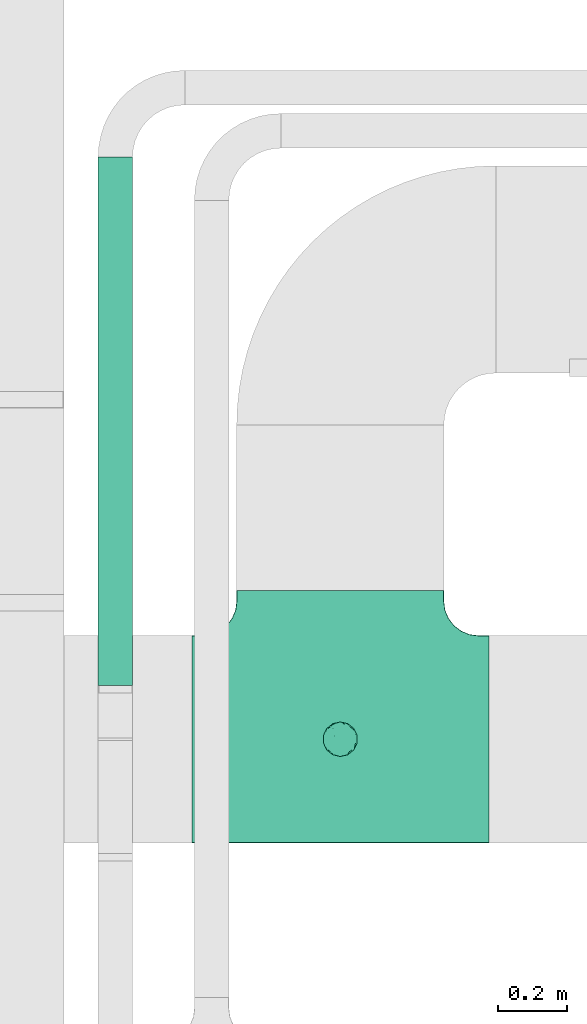
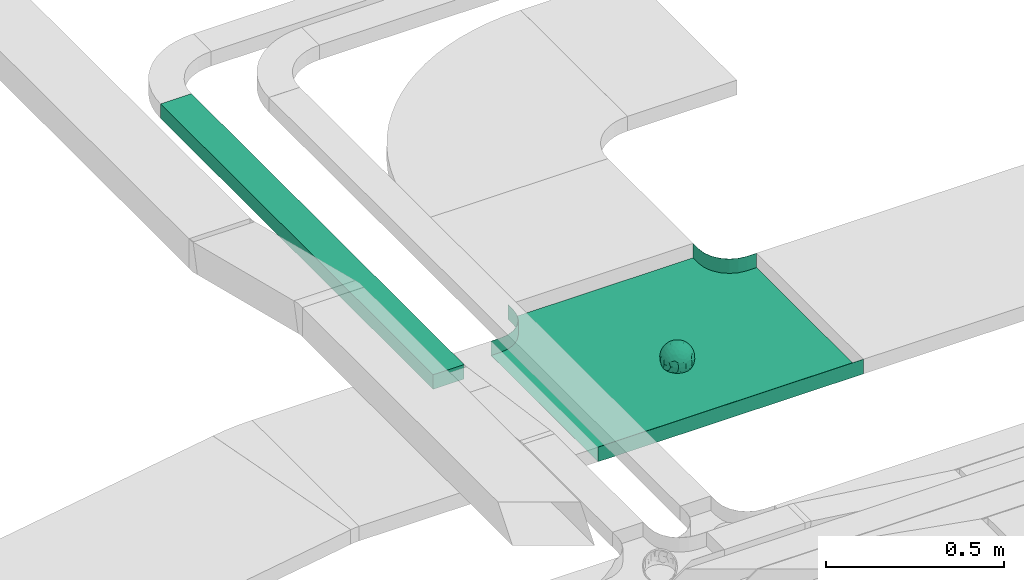
# One storey, part 4 of 38: 1 flow fitting, 1 flow segment.
"""IFC2X3 building model written with IfcOpenShell, lengths in millimetres."""

from ifc_helpers import new_model, entity, si_unit, converted_unit, derived_unit, direction, frame, frame_2d, origin, place, context, subcontext, project, spatial, rectangle, extrude, faceted_brep, source, transform, mapped, material, material_list, type_object, type_shapes, element, save


model = new_model("IFC2X3")

# Units and contexts
model_context = context("Model", 3, precision=0.01, world=origin(), true_north=direction((6.12303176911189e-17, 1.0)))
body_context = subcontext(model_context, "Body", "Model", "MODEL_VIEW")
ifc_project = project(units=[si_unit("LENGTHUNIT", "METRE", prefix="MILLI"), si_unit("AREAUNIT", "SQUARE_METRE"), si_unit("VOLUMEUNIT", "CUBIC_METRE"), converted_unit("PLANEANGLEUNIT", "DEGREE", entity("IfcRatioMeasure", 0.0174532925199433), si_unit("PLANEANGLEUNIT", "RADIAN"), dimensions=[0, 0, 0, 0, 0, 0, 0]), si_unit("MASSUNIT", "GRAM", prefix="KILO"), derived_unit("MASSDENSITYUNIT", [(si_unit("MASSUNIT", "GRAM", prefix="KILO"), 1), (si_unit("LENGTHUNIT", "METRE"), -3)]), derived_unit("MOMENTOFINERTIAUNIT", [(si_unit("LENGTHUNIT", "METRE"), 4)]), si_unit("TIMEUNIT", "SECOND"), si_unit("FREQUENCYUNIT", "HERTZ"), si_unit("THERMODYNAMICTEMPERATUREUNIT", "DEGREE_CELSIUS"), derived_unit("THERMALTRANSMITTANCEUNIT", [(si_unit("MASSUNIT", "GRAM", prefix="KILO"), 1), (si_unit("THERMODYNAMICTEMPERATUREUNIT", "KELVIN"), -1), (si_unit("TIMEUNIT", "SECOND"), -3)]), derived_unit("VOLUMETRICFLOWRATEUNIT", [(si_unit("LENGTHUNIT", "METRE"), 3), (si_unit("TIMEUNIT", "SECOND"), -1)]), derived_unit("MASSFLOWRATEUNIT", [(si_unit("MASSUNIT", "GRAM", prefix="KILO"), 1), (si_unit("TIMEUNIT", "SECOND"), -1)]), derived_unit("ROTATIONALFREQUENCYUNIT", [(si_unit("TIMEUNIT", "SECOND"), -1)]), si_unit("ELECTRICCURRENTUNIT", "AMPERE"), si_unit("ELECTRICVOLTAGEUNIT", "VOLT"), si_unit("POWERUNIT", "WATT"), si_unit("FORCEUNIT", "NEWTON", prefix="KILO"), si_unit("ILLUMINANCEUNIT", "LUX"), si_unit("LUMINOUSFLUXUNIT", "LUMEN"), si_unit("LUMINOUSINTENSITYUNIT", "CANDELA"), derived_unit("USERDEFINED", [(si_unit("MASSUNIT", "GRAM", prefix="KILO"), -1), (si_unit("LENGTHUNIT", "METRE"), -2), (si_unit("TIMEUNIT", "SECOND"), 3), (si_unit("LUMINOUSFLUXUNIT", "LUMEN"), 1)]), derived_unit("LINEARVELOCITYUNIT", [(si_unit("LENGTHUNIT", "METRE"), 1), (si_unit("TIMEUNIT", "SECOND"), -1)]), si_unit("PRESSUREUNIT", "PASCAL"), derived_unit("USERDEFINED", [(si_unit("LENGTHUNIT", "METRE"), -2), (si_unit("MASSUNIT", "GRAM", prefix="KILO"), 1), (si_unit("TIMEUNIT", "SECOND"), -2)]), derived_unit("LINEARFORCEUNIT", [(si_unit("MASSUNIT", "GRAM", prefix="KILO"), 1), (si_unit("LENGTHUNIT", "METRE"), 1), (si_unit("TIMEUNIT", "SECOND"), -2), (si_unit("LENGTHUNIT", "METRE"), -1)]), derived_unit("PLANARFORCEUNIT", [(si_unit("MASSUNIT", "GRAM", prefix="KILO"), 1), (si_unit("LENGTHUNIT", "METRE"), 1), (si_unit("TIMEUNIT", "SECOND"), -2), (si_unit("LENGTHUNIT", "METRE"), -2)])], contexts=[model_context])

# Site, building, storey
site_placement = place(None, frame((0.0, -0.00077364408347762, 0.0)))
site = spatial("IfcSite", under=ifc_project, at=site_placement, CompositionType="ELEMENT")
building_placement = place(site_placement, origin())
building = spatial("IfcBuilding", under=site, at=building_placement, CompositionType="ELEMENT")
storey_placement = place(building_placement, frame((0.0, 0.0, 4200.0)))
storey = spatial("IfcBuildingStorey", under=building, at=storey_placement, CompositionType="ELEMENT", Elevation=4200.0)

# Flow segment
cable_carrier_segment_type = type_object("IfcCableCarrierSegmentType", PredefinedType="CABLETRAYSEGMENT")
flow_segment_placement = place(storey_placement, frame((14783.0702916724, 13087.0410478205, 2750.0)))
element("IfcFlowSegment", 1, at=flow_segment_placement, inside=storey, type_object=cable_carrier_segment_type, context=body_context, shape_type="SweptSolid", body=[
    extrude(rectangle(XDim=1530.08411261918, YDim=99.9999999999989, at=frame_2d((0.0, -1.08357767203415e-12), x_axis=(1.0, 0.0))), frame((50.0, 765.042056309591, 0.0), z_axis=(0.0, 0.0, 1.0), x_axis=(0.0, -1.0, 0.0)), (0.0, 0.0, 1.0), 49.9999999999995),
])

# Flow fitting
ifc_material_1 = material()
ifc_material_2 = material()
ifc_material_list = material_list([ifc_material_1, ifc_material_2])
cable_carrier_fitting_type = type_object("IfcCableCarrierFittingType", PredefinedType="NOTDEFINED", material=ifc_material_1)
shared_shape = source(origin(), body_context, "Body", "Brep", [
    faceted_brep([(43.65414201495, -13.6159823941412, -20.221792907194), (44.7734537304832, 0.0, -22.2561865791168), (48.2627667869764, -5.5982238187369, -11.8053052540677), (16.6591030416451, 5.32882774998004, -46.8409850521773), (11.5556000970565, -8.32997143460759, -47.9278591457525), (2.01883462715812, 2.6979389970297, -49.8863250993269), (-7.81264210311725, -35.946586740035, -33.8645171988286), (-17.2052206683237, -38.2719861359275, -27.1888848422606), (-11.1277274207927, -27.3202044092451, -40.3705352142543), (37.7030088371667, -7.24923843471304, -32.0301680723234), (10.6384317789277, 26.5155476513889, -41.0335168128579), (19.2127839264957, 19.8412508508062, -41.6796556903778), (10.4192511908907, 17.8098221318595, -45.5439286870577), (48.7463956090969, 0.0, 0.0), (48.0667721403428, 6.51594663441988, -12.1296271775358), (-37.4554170352858, 12.1627069007925, -30.8084451986326), (-31.3452178059555, 12.1462454498318, -37.0127821457472), (-38.0909108580228, 3.52194087904066, -32.1974912446565), (48.7463956090969, 11.1260466978072, 0.0), (9.66670567763161, 42.5651334019307, -24.3877883338551), (17.4761229293595, 37.974251726212, -27.4324868211278), (8.3452685270067, 35.3634447252368, -34.3479733081336), (36.7018152786982, 20.4309971840494, -27.121045505536), (28.2201055605836, 12.5803931374896, -39.3110588849404), (28.3969378462537, 24.0066360557188, -33.4259681422047), (37.1036906899333, 7.75177236926259, -32.6071489449891), (30.3928805396455, 38.1114667440203, 0.0), (34.7422273315263, 34.6429784184742, 0.0), (32.9402906787036, 32.1278050479557, -19.5637775698511), (26.0435337477646, 41.5799550695664, 0.0), (-44.7734518080776, 0.0, -22.2561904464559), (-35.9183276906112, -8.71634506105637, -33.6734177755349), (-42.698067512074, -12.1858404892465, -22.9865247983333), (5.42354673897514, -48.7621108487887, 0.0), (2.92058716488888e-07, -48.7843224693665, -10.9585528791684), (7.58713024513234, -47.4313421101439, -13.8817592643935), (33.995370401777, -31.6485911362954, -18.5116576873667), (40.0066375577234, -26.2448741379086, -14.5146661281262), (30.3928805396453, -38.1114667440373, 0.0), (-47.5540080368347, -8.6499737676748, -12.798213682019), (43.918984866252, -21.1502683953847, 0.0), (-47.5463631702337, 8.67950108284767, -12.8066236860544), (-43.9189848662407, 21.1502683953677, 0.0), (-41.5587306666804, 23.544384411141, -14.7828910593852), (-36.7018137075475, 20.43099797302, -27.1210470373429), (-42.6812093094125, 12.162707383776, -23.0300438771125), (-0.0435489182880873, -44.6798423199703, -22.4434799831651), (43.3459115209922, 13.125713179152, -21.1860238825719), (-9.67158541810518, -42.815796006327, -23.9430166822217), (2.9348104480415, -38.3026865671621, -32.0045479482528), (10.5768620896568, -32.3565839798164, -36.6221444141874), (17.476122931187, -37.9742517249799, -27.4324868216925), (29.4150529887209, -14.2918330913411, -37.8219270339311), (29.2594402117981, 0.0, -40.5448536622337), (-34.742227331515, 34.6429784184742, 0.0), (-35.5934709721032, 30.8679809236437, -16.7413433706631), (16.2706402169142, 46.2863325463322, 0.0), (15.3978227309257, 45.3692296018892, -14.301750259225), (10.8470934779447, 47.524221697552, 0.0), (-22.0930685137321, 42.2576087042555, -15.0396419586498), (-16.2706402169028, 46.2863325463322, 0.0), (-15.3976096147999, 45.3685960862683, -14.3039892096614), (-35.5741674477324, -30.877857614309, -16.7641438657341), (-34.7422273315149, -34.6429784184913, 0.0), (-41.544749127214, -23.5699215759022, -14.7814957586296), (-21.2012609977656, -29.9118129495041, -33.9969113035032), (-22.0930685137892, -42.2576087036302, -15.0396419603704), (-28.5890959469058, -35.7745555449591, -20.0709932115786), (27.967317375364, -26.9235432392394, -31.5111405422078), (26.5630985649032, -36.7540375314827, -21.0604491824418), (-4.69743067705244, -12.8233951627736, -48.0988012484001), (-3.71385705669819, -22.0483048804436, -44.7222485756373), (7.046128924104e-07, -29.8515321197025, -40.1109215813634), (-8.78090686085946, 23.4705297392872, -43.266960933916), (-10.7087237416586, 12.1533783795858, -47.3034737602475), (-19.1851128431225, 19.8122800241045, -41.7061746680507), (19.2127839279743, -19.841250849511, -41.6796556903208), (10.2736167511021, -43.2535488218696, -22.8819429499797), (-16.2706402169027, -46.2863325463492, 0.0), (-15.4179487650123, -45.4307793041134, -14.0830091848577), (-10.8470934779332, -47.524221697569, 0.0), (-21.6941869558721, -45.0484433951294, 0.0), (-26.043533747753, -41.5799550695834, 0.0), (-30.3928805396339, -38.1114667440373, 0.0), (-26.9077773704145, -11.7097120961444, -40.4827637348157), (-28.5735237959864, -22.531789977659, -34.2909926698312), (-14.3485559949731, 0.554718003800719, -47.8937493708156), (20.3912706461748, 29.6966950280778, -34.6742323035854), (25.8798715159051, 35.5620355309087, -23.7817972243053), (-1.90439589452332, 38.2956374757213, -32.090768557389), (-0.0435489197807358, 44.6798423204566, -22.4434799821603), (-9.54280395759116, 42.6678856642021, -24.2566779582937), (-10.1209262269152, 33.0365306692783, -36.140759450321), (-17.2052206685055, 38.2719861378047, -27.1888848394794), (-28.5890959468196, 35.7745555453602, -20.0709932109564), (-30.3928805396341, 38.1114667440203, 0.0), (-26.0435337477532, 41.5799550695664, 0.0), (-21.6941869558723, 45.0484433951125, 0.0), (0.920553890736952, 16.9936143333855, -47.0145685125519), (7.01705705346737e-07, 29.8515321215381, -40.1109215799846), (-28.4299335912282, 23.6392950735915, -33.6589156750601), (22.0754283900311, -42.7194435884069, -13.7012627481666), (0.0, -50.0, 0.0), (-7.98433520770671, 47.2879675743241, -14.1456181900809), (-10.8470934779333, 47.524221697552, 0.0), (-5.42354673896381, 48.7621108487718, 0.0), (-39.0915741233958, -31.1744900929452, 0.0), (-36.7018137083218, -20.4309979729983, -27.1210470363242), (-20.0503020227076, 29.8835350153312, -34.7125297808217), (48.7463956090969, -11.1260466978243, 0.0), (36.7018152787698, -20.430997183803, -27.1210455056374), (39.0915741234071, -31.1744900929452, 0.0), (43.9189848662521, 21.1502683953677, 0.0), (41.0372234357161, 24.481336168204, -14.7176924857918), (21.4315363761966, -9.86715979165204, -44.0831986838696), (19.8461085062156, -30.3026908878047, -34.4656191315041), (26.0435337477644, -41.5799550695834, 0.0), (8.27678352490751, -22.6176025005053, -43.8171075221857), (-19.1851128386707, -19.8122800229913, -41.7061746706354), (-17.559283921422, -9.66340012518247, -45.8070982074481), (-29.2594384269524, -1.64502744759432e-09, -40.5448549502702), (-22.2759109836818, 8.45458562997746, -43.957977338265), (21.6941869558835, -45.0484433951294, 0.0), (-7.7537430917927, -47.3248906716555, -14.1504131029038), (22.0929359888287, 42.3611643932195, -14.7456410726513), (21.6941869558837, 45.0484433951125, 0.0), (7.94480963874029, 47.2524194975214, -14.285966940796), (5.42354673897518, 48.7621108487718, 0.0), (-43.9189848662406, -21.1502683953848, 0.0), (-39.0915741233959, 31.1744900929281, 0.0), (-48.7463956090855, 11.1260466978072, 0.0), (-48.7463956090855, -11.1260466978243, 0.0), (-48.7463956090855, 0.0, 0.0), (0.0, 50.0, 0.0), (2.95674852821199e-07, 48.76542105366, -11.0423597776141), (-5.42354673896377, -48.7621108487887, 0.0), (16.2706402169141, -46.2863325463492, 0.0), (10.8470934779446, -47.524221697569, 0.0), (39.0915741234072, 31.1744900929281, 0.0), (34.7422273315262, -34.6429784184913, 0.0), (-43.6541417785539, -13.6159824952714, 20.2217933494142), (-44.7734534735007, 0.0, 22.2561870960884), (-48.2627667188257, -5.59822380837423, 11.8053055375658), (-16.6591016552529, 5.32882757852047, 46.8409855647676), (-11.5555985538933, -8.32997141356845, 47.9278595214841), (-2.01883285210585, 2.69793886619285, 49.8863251782511), (7.81264298940045, -35.9465866899564, 33.8645170475355), (17.2052219498432, -38.2719853643866, 27.1888851173795), (11.1277291939633, -27.3202042660781, 40.370534822402), (-37.7030082707847, -7.24923849358482, 32.0301687256941), (-10.6384306361632, 26.5155474098453, 41.0335172652288), (-19.2127828542464, 19.8412506695278, 41.6796562709507), (-10.419249902145, 17.8098220464058, 45.5439290153173), (-48.0667720467311, 6.51594672713361, 12.1296274986609), (37.4554198551597, 12.1627053911885, 30.8084423663635), (31.3452204336626, 12.1462444514283, 37.0127802480704), (38.0909129847824, 3.52193921618223, 32.1974889105362), (-9.66670492251031, 42.565133342123, 24.3877887375616), (-17.4761222809685, 37.9742516795029, 27.4324872988574), (-8.34526747232003, 35.3634445391436, 34.3479737559899), (-36.7018147879525, 20.4309972885889, 27.1210460908894), (-28.2201045883605, 12.5803929822385, 39.3110596325575), (-28.3969371324566, 24.0066357536882, 33.4259689655335), (-37.1036900366786, 7.75177247673037, 32.6071496627812), (-32.9402901163369, 32.1278052689131, 19.5637781538672), (44.773453728735, 0.0, 22.2561865826485), (35.9183286182219, -8.71634518545332, 33.6734167539099), (42.6980684782056, -12.1858381773451, 22.9865242293622), (-5.1564557811304e-08, -48.7843224155168, 10.9585531189064), (-7.58712982046247, -47.4313421866568, 13.8817592350767), (-33.9953700157816, -31.6485912778883, 18.5116581541388), (-40.0066373233245, -26.2448743223541, 14.5146664406737), (47.5540088657557, -8.64997340643016, 12.7982108462298), (47.5463641063755, 8.67950029611492, 12.8066207437518), (41.5587323717035, 23.5443822102692, 14.7828897714275), (36.7018153946169, 20.4309968399072, 27.121045607934), (42.6812105193328, 12.1627054070682, 23.0300426787683), (0.0435498934198039, -44.6798421141237, 22.4434803910813), (-43.3459112327239, 13.1257132261269, 21.1860244432478), (9.6715868653752, -42.8157959611257, 23.9430161784588), (-2.93481023367521, -38.3026862522726, 32.0045483447802), (-10.5768615382775, -32.3565831315815, 36.6221453228799), (-17.4761222811971, -37.9742516793303, 27.4324872989742), (-29.4150522011614, -14.2918331221065, 37.8219276348162), (-29.259439267976, 0.0, 40.5448543433553), (35.593472529025, 30.867979902287, 16.7413419437535), (-15.3978225621776, 45.3692295068837, 14.3017507422931), (22.0930688164668, 42.2576085856364, 15.0396418472572), (15.3976099169387, 45.3685960801975, 14.3039889037045), (35.5741692798952, -30.8778564526781, 16.7641421174582), (41.5447510295928, -23.5699190140567, 14.7814944968718), (21.2012629219892, -29.9118119699372, 33.9969109653959), (22.0930688164889, -42.2576085855628, 15.039641847479), (28.5890966709526, -35.7745557157875, 20.0709918757936), (-27.9673166448933, -26.9235432178776, 31.5111412087844), (-26.5630981091642, -36.7540374223405, 21.0604499477277), (4.69743244094294, -12.8233948182002, 48.0988011680158), (3.71385918047916, -22.0483045188225, 44.7222485775695), (6.0892732202368e-07, -29.8515316280668, 40.1109219472655), (8.78090833347225, 23.4705290601204, 43.2669610034903), (10.7087255323208, 12.1533779204354, 47.3034734728551), (19.1851144535653, 19.8122792782791, 41.7061742815566), (-19.212782854423, -19.8412506693283, 41.6796562709723), (-10.2736163541564, -43.2535491498667, 22.8819425082012), (15.4179491053271, -45.430779442795, 14.0830083649343), (26.9077783310918, -11.7097109554472, 40.4827634262511), (28.5735255699879, -22.531788297607, 34.2909922955619), (14.3485579041194, 0.554717908736034, 47.893748799971), (-20.3912698186306, 29.6966949125693, 34.674232889184), (-25.8798708903081, 35.5620354347035, 23.7817980489561), (1.90439718168615, 38.2956370656312, 32.0907689704016), (0.0435498935700709, 44.6798421141929, 22.4434803909095), (9.54280511870019, 42.6678852802435, 24.2566781769111), (10.1209277017953, 33.036529901429, 36.1407597392074), (17.2052219497738, 38.2719853646937, 27.1888851169673), (28.5890966709116, 35.7745557157488, 20.0709918758907), (-0.920552500958269, 16.993613961591, 47.0145686741652), (6.09264554473049e-07, 29.8515316283504, 40.1109219470418), (28.4299352793349, 23.6392936643312, 33.6589152389788), (-22.0754282965694, -42.7194435788052, 13.7012629286858), (7.9843354212563, 47.2879674404261, 14.1456185171795), (36.7018153946056, -20.4309968401043, 27.1210456078136), (20.0503035663584, 29.8835340747136, 34.7125296989797), (-36.7018147879654, -20.4309972885437, 27.1210460909186), (-41.0372232425556, 24.4813362747081, 14.7176928472045), (-21.4315352776288, -9.8671595900376, 44.0831992630873), (-19.8461080318002, -30.3026912052829, 34.4656191255603), (-8.27678185920825, -22.617601585775, 43.8171083090061), (19.1851144530605, -19.8122792780652, 41.7061742818985), (17.5592847966676, -9.6634000411993, 45.8070978896755), (29.259440221343, 0.0, 40.5448536553604), (22.2759127990671, 8.45458631346954, 43.9579762868721), (7.75374356219277, -47.3248906381916, 14.1504129570858), (-22.0929358819219, 42.3611643749655, 14.7456412852645), (-7.94480944914509, 47.2524194744515, 14.2859671225497), (-5.23333520595152e-08, 48.7654210084985, 11.0423599770715)], [[[0, 1, 2]], [[3, 4, 5]], [[6, 7, 8]], [[1, 0, 9]], [[10, 11, 12]], [[13, 2, 14]], [[15, 16, 17]], [[14, 18, 13]], [[19, 20, 21]], [[22, 23, 24]], [[1, 9, 25]], [[26, 27, 28, 29]], [[30, 31, 32]], [[33, 34, 35]], [[36, 37, 38]], [[32, 39, 30]], [[2, 40, 0]], [[23, 22, 25]], [[41, 42, 43]], [[44, 15, 45]], [[46, 35, 34]], [[25, 22, 47]], [[31, 30, 17]], [[48, 49, 46]], [[50, 51, 49]], [[52, 53, 9]], [[43, 54, 55]], [[56, 57, 58]], [[59, 60, 61]], [[62, 63, 64]], [[8, 7, 65]], [[7, 66, 67]], [[68, 36, 69]], [[70, 5, 4]], [[8, 71, 72]], [[73, 74, 75]], [[68, 76, 52]], [[77, 46, 49]], [[78, 79, 80]], [[7, 6, 48]], [[67, 81, 82, 83]], [[84, 85, 31]], [[85, 65, 67]], [[70, 86, 5]], [[23, 3, 11]], [[21, 87, 10]], [[21, 20, 87]], [[28, 24, 88]], [[19, 89, 90]], [[91, 90, 89]], [[91, 92, 93]], [[94, 95, 96, 97]], [[98, 99, 10]], [[100, 16, 44]], [[77, 51, 101]], [[33, 102, 34]], [[103, 91, 61]], [[93, 59, 61]], [[104, 105, 103]], [[106, 64, 63]], [[107, 31, 85]], [[100, 94, 108]], [[108, 93, 92]], [[43, 55, 44]], [[0, 40, 37]], [[2, 13, 109]], [[2, 1, 14]], [[110, 9, 0]], [[2, 109, 40]], [[37, 40, 111]], [[47, 14, 1]], [[112, 14, 47]], [[113, 112, 47]], [[112, 18, 14]], [[47, 22, 113]], [[52, 9, 110]], [[53, 25, 9]], [[25, 47, 1]], [[23, 25, 53]], [[68, 52, 110]], [[76, 4, 114]], [[51, 115, 69]], [[50, 115, 51]], [[110, 36, 68]], [[3, 23, 53]], [[23, 11, 24]], [[52, 76, 114]], [[98, 12, 5]], [[11, 87, 24]], [[24, 28, 22]], [[87, 88, 24]], [[36, 116, 69]], [[28, 27, 113]], [[114, 3, 53]], [[76, 115, 117]], [[70, 4, 117]], [[118, 84, 119]], [[119, 70, 118]], [[120, 16, 121]], [[37, 36, 110]], [[116, 36, 38]], [[116, 122, 69]], [[34, 123, 46]], [[10, 87, 11]], [[87, 20, 88]], [[12, 98, 10]], [[10, 99, 21]], [[74, 5, 86]], [[73, 75, 108]], [[124, 56, 125]], [[124, 29, 88]], [[89, 21, 99]], [[21, 89, 19]], [[92, 89, 99]], [[89, 92, 91]], [[126, 127, 58]], [[88, 29, 28]], [[20, 57, 124]], [[88, 20, 124]], [[57, 20, 19]], [[73, 92, 99]], [[92, 73, 108]], [[99, 98, 73]], [[74, 86, 121]], [[73, 98, 74]], [[5, 74, 98]], [[100, 108, 75]], [[94, 93, 108]], [[86, 120, 121]], [[100, 44, 55]], [[75, 16, 100]], [[17, 16, 120]], [[31, 17, 120]], [[17, 30, 45]], [[84, 31, 120]], [[31, 107, 32]], [[41, 45, 30]], [[43, 44, 45]], [[107, 64, 32]], [[39, 64, 128]], [[30, 39, 41]], [[129, 43, 42]], [[41, 130, 42]], [[43, 45, 41]], [[62, 83, 63]], [[95, 94, 55]], [[100, 55, 94]], [[64, 107, 62]], [[131, 39, 128]], [[64, 106, 128]], [[85, 62, 107]], [[67, 83, 62]], [[39, 32, 64]], [[130, 41, 132]], [[59, 97, 60]], [[133, 127, 134]], [[59, 94, 97]], [[104, 61, 60]], [[94, 59, 93]], [[126, 134, 127]], [[126, 58, 57]], [[19, 90, 126]], [[134, 105, 133]], [[126, 90, 134]], [[103, 90, 91]], [[105, 134, 103]], [[90, 103, 134]], [[119, 120, 86]], [[84, 118, 85]], [[65, 85, 118]], [[62, 85, 67]], [[8, 65, 118]], [[67, 65, 7]], [[71, 118, 70]], [[8, 72, 6]], [[49, 6, 72]], [[6, 49, 48]], [[50, 49, 72]], [[77, 49, 51]], [[101, 69, 122]], [[123, 34, 135]], [[101, 122, 136]], [[137, 77, 136]], [[78, 81, 66]], [[7, 79, 66]], [[67, 66, 81]], [[79, 7, 48]], [[35, 137, 33]], [[123, 80, 79]], [[135, 34, 102]], [[35, 46, 77]], [[80, 123, 135]], [[46, 123, 48]], [[117, 50, 72]], [[115, 76, 68]], [[117, 72, 71]], [[4, 76, 117]], [[39, 132, 41]], [[39, 131, 132]], [[137, 35, 77]], [[124, 57, 56]], [[126, 57, 19]], [[103, 61, 104]], [[61, 91, 93]], [[77, 101, 136]], [[51, 69, 101]], [[28, 113, 22]], [[112, 113, 138]], [[16, 75, 121]], [[74, 121, 75]], [[66, 79, 78]], [[123, 79, 48]], [[0, 37, 110]], [[37, 111, 139, 38]], [[29, 124, 125]], [[115, 50, 117]], [[69, 115, 68]], [[120, 119, 84]], [[70, 119, 86]], [[11, 3, 12]], [[5, 12, 3]], [[118, 71, 8]], [[117, 71, 70]], [[3, 114, 4]], [[53, 52, 114]], [[27, 138, 113]], [[45, 15, 17]], [[44, 16, 15]], [[55, 54, 95]], [[43, 129, 54]], [[140, 141, 142]], [[143, 144, 145]], [[146, 147, 148]], [[141, 140, 149]], [[150, 151, 152]], [[132, 142, 153]], [[154, 155, 156]], [[153, 130, 132]], [[157, 158, 159]], [[160, 161, 162]], [[141, 149, 163]], [[95, 54, 164, 96]], [[165, 166, 167]], [[135, 168, 169]], [[170, 171, 83]], [[167, 172, 165]], [[142, 141, 153]], [[161, 160, 163]], [[173, 112, 174]], [[175, 154, 176]], [[177, 169, 168]], [[163, 160, 178]], [[166, 165, 156]], [[179, 180, 177]], [[181, 182, 180]], [[183, 184, 149]], [[174, 27, 185]], [[60, 186, 104]], [[187, 56, 188]], [[189, 139, 190]], [[148, 147, 191]], [[147, 192, 193]], [[194, 170, 195]], [[196, 145, 144]], [[148, 197, 198]], [[199, 200, 201]], [[194, 202, 183]], [[203, 177, 180]], [[136, 204, 137]], [[147, 146, 179]], [[193, 122, 116, 38]], [[205, 206, 166]], [[206, 191, 193]], [[196, 207, 145]], [[161, 143, 151]], [[159, 208, 150]], [[159, 158, 208]], [[164, 162, 209]], [[157, 210, 211]], [[212, 211, 210]], [[212, 213, 214]], [[215, 26, 29, 125]], [[216, 217, 150]], [[218, 155, 175]], [[203, 182, 219]], [[135, 102, 168]], [[220, 212, 188]], [[214, 187, 188]], [[58, 127, 220]], [[111, 190, 139]], [[221, 166, 206]], [[218, 215, 222]], [[222, 214, 213]], [[174, 185, 175]], [[171, 140, 128]], [[132, 131, 142]], [[142, 128, 140]], [[223, 149, 140]], [[142, 131, 128]], [[171, 128, 106]], [[178, 153, 141]], [[42, 153, 178]], [[224, 42, 178]], [[42, 130, 153]], [[178, 160, 224]], [[183, 149, 223]], [[184, 163, 149]], [[163, 178, 141]], [[161, 163, 184]], [[194, 183, 223]], [[202, 144, 225]], [[182, 226, 195]], [[181, 226, 182]], [[223, 170, 194]], [[143, 161, 184]], [[161, 151, 162]], [[183, 202, 225]], [[216, 152, 145]], [[151, 208, 162]], [[162, 164, 160]], [[208, 209, 162]], [[170, 82, 195]], [[164, 54, 224]], [[225, 143, 184]], [[202, 226, 227]], [[196, 144, 227]], [[228, 205, 229]], [[229, 196, 228]], [[230, 155, 231]], [[171, 170, 223]], [[82, 170, 83]], [[82, 81, 195]], [[168, 232, 177]], [[150, 208, 151]], [[208, 158, 209]], [[152, 216, 150]], [[150, 217, 159]], [[200, 145, 207]], [[199, 201, 222]], [[233, 60, 97]], [[233, 96, 209]], [[210, 159, 217]], [[159, 210, 157]], [[213, 210, 217]], [[210, 213, 212]], [[234, 105, 104]], [[209, 96, 164]], [[158, 186, 233]], [[209, 158, 233]], [[186, 158, 157]], [[199, 213, 217]], [[213, 199, 222]], [[217, 216, 199]], [[200, 207, 231]], [[199, 216, 200]], [[145, 200, 216]], [[218, 222, 201]], [[215, 214, 222]], [[207, 230, 231]], [[218, 175, 185]], [[201, 155, 218]], [[156, 155, 230]], [[166, 156, 230]], [[156, 165, 176]], [[205, 166, 230]], [[166, 221, 167]], [[173, 176, 165]], [[174, 175, 176]], [[221, 190, 167]], [[172, 190, 40]], [[165, 172, 173]], [[138, 174, 112]], [[173, 18, 112]], [[174, 176, 173]], [[189, 38, 139]], [[26, 215, 185]], [[218, 185, 215]], [[190, 221, 189]], [[109, 172, 40]], [[190, 111, 40]], [[206, 189, 221]], [[193, 38, 189]], [[172, 167, 190]], [[18, 173, 13]], [[187, 125, 56]], [[133, 105, 235]], [[187, 215, 125]], [[58, 188, 56]], [[215, 187, 214]], [[234, 235, 105]], [[234, 104, 186]], [[157, 211, 234]], [[235, 127, 133]], [[234, 211, 235]], [[220, 211, 212]], [[127, 235, 220]], [[211, 220, 235]], [[229, 230, 207]], [[205, 228, 206]], [[191, 206, 228]], [[189, 206, 193]], [[148, 191, 228]], [[193, 191, 147]], [[197, 228, 196]], [[148, 198, 146]], [[180, 146, 198]], [[146, 180, 179]], [[181, 180, 198]], [[203, 180, 182]], [[219, 195, 81]], [[232, 168, 33]], [[219, 81, 78]], [[80, 203, 78]], [[136, 122, 192]], [[147, 204, 192]], [[193, 192, 122]], [[204, 147, 179]], [[169, 80, 135]], [[232, 137, 204]], [[33, 168, 102]], [[169, 177, 203]], [[137, 232, 33]], [[177, 232, 179]], [[227, 181, 198]], [[226, 202, 194]], [[227, 198, 197]], [[144, 202, 227]], [[172, 13, 173]], [[172, 109, 13]], [[80, 169, 203]], [[233, 186, 60]], [[234, 186, 157]], [[220, 188, 58]], [[188, 212, 214]], [[203, 219, 78]], [[182, 195, 219]], [[164, 224, 160]], [[42, 224, 129]], [[155, 201, 231]], [[200, 231, 201]], [[192, 204, 136]], [[232, 204, 179]], [[140, 171, 223]], [[171, 106, 63, 83]], [[96, 233, 97]], [[226, 181, 227]], [[195, 226, 194]], [[230, 229, 205]], [[196, 229, 207]], [[151, 143, 152]], [[145, 152, 143]], [[228, 197, 148]], [[227, 197, 196]], [[143, 225, 144]], [[184, 183, 225]], [[54, 129, 224]], [[176, 154, 156]], [[175, 155, 154]], [[185, 27, 26]], [[174, 138, 27]]]),
    faceted_brep([(-303.407417371086, -374.118095489752, 25.0), (-300.0, -400.0, 25.0), (-300.0, -430.0, 25.0), (-299.199999999993, -430.0, 25.0), (-299.199999999993, -400.0, 25.0), (-302.634676710055, -373.911040253671, 25.0), (-312.704639298522, -349.600000000004, 25.0), (-328.72363645639, -328.723636456399, 25.0), (-349.599999999995, -312.704639298532, 25.0), (-373.911040253662, -302.634676710065, 25.0), (-400.0, -299.200000000004, 25.0), (-430.0, -299.200000000004, 25.0), (-430.0, -300.0, 25.0), (-400.0, -300.0, 25.0), (-374.118095489745, -303.407417371099, 25.0), (-350.0, -313.397459621561, 25.0), (-329.28932188134, -329.289321881349, 25.0), (-313.39745962155, -350.0, 25.0), (430.0, -300.0, 25.0), (430.0, -299.200000000004, 25.0), (400.0, -299.200000000004, 25.0), (373.911040253717, -302.634676710066, 25.0), (349.600000000045, -312.704639298531, 25.0), (328.723636456434, -328.723636456398, 25.0), (312.704639298558, -349.600000000001, 25.0), (302.634676710081, -373.911040253668, 25.0), (299.200000000007, -400.0, 25.0), (299.200000000007, -430.0, 25.0), (300.0, -430.0, 25.0), (300.0, -400.0, 25.0), (303.407417371113, -374.11809548975, 25.0), (313.397459621587, -350.0, 25.0), (329.289321881385, -329.289321881348, 25.0), (350.0, -313.397459621561, 25.0), (374.1180954898, -303.4074173711, 25.0), (400.0, -300.0, 25.0), (430.0, 299.199999999995, 25.0), (430.0, 300.0, 25.0), (-430.0, 300.0, 25.0), (-430.0, 299.199999999995, 25.0), (-430.0, -300.0, -25.0), (-430.0, 300.0, -25.0), (430.0, 300.0, -25.0), (430.0, -300.0, -25.0), (400.0, -300.0, -25.0), (374.1180954898, -303.4074173711, -25.0), (350.0, -313.397459621561, -25.0), (329.289321881385, -329.289321881348, -25.0), (313.397459621587, -350.0, -25.0), (303.407417371113, -374.11809548975, -25.0), (300.0, -400.0, -25.0), (300.0, -430.0, -25.0), (-300.0, -430.0, -25.0), (-300.0, -400.0, -25.0), (-303.407417371086, -374.118095489752, -25.0), (-313.39745962155, -350.0, -25.0), (-329.28932188134, -329.289321881349, -25.0), (-350.0, -313.397459621561, -25.0), (-374.118095489745, -303.407417371099, -25.0), (-400.0, -300.0, -25.0), (-300.0, -400.0, -24.199999999986), (299.200000000007, -430.0, -24.199999999986), (-299.199999999993, -430.0, -24.199999999986), (-299.199999999993, -400.0, -24.199999999986), (-400.0, -299.200000000004, -24.199999999986), (-430.0, -299.200000000004, -24.199999999986), (430.0, -299.200000000004, -24.199999999986), (400.0, -299.200000000004, -24.199999999986), (-430.0, 299.199999999995, -24.199999999986), (-400.0, -300.0, -24.199999999986), (400.0, -300.0, -24.199999999986), (430.0, 299.199999999995, -24.199999999986), (299.200000000007, -400.0, -24.199999999986), (300.0, -400.0, -24.199999999986), (-373.911040253662, -302.634676710065, -24.199999999986), (-349.599999999995, -312.704639298532, -24.199999999986), (-328.72363645639, -328.7236364564, -24.199999999986), (-312.704639298522, -349.600000000004, -24.199999999986), (-302.634676710055, -373.911040253671, -24.199999999986), (302.634676710081, -373.911040253668, -24.199999999986), (312.704639298557, -349.600000000001, -24.199999999986), (328.723636456434, -328.723636456398, -24.199999999986), (349.600000000044, -312.704639298532, -24.199999999986), (373.911040253716, -302.634676710066, -24.199999999986)], [[[0, 1, 2, 3, 4, 5, 6, 7, 8, 9, 10, 11, 12, 13, 14, 15, 16, 17]], [[18, 19, 20, 21, 22, 23, 24, 25, 26, 27, 28, 29, 30, 31, 32, 33, 34, 35]], [[36, 37, 38, 39]], [[40, 41, 42, 43, 44, 45, 46, 47, 48, 49, 50, 51, 52, 53, 54, 55, 56, 57, 58, 59]], [[2, 1, 60, 53, 52]], [[3, 2, 52, 51, 28, 27, 61, 62]], [[4, 3, 62, 63]], [[11, 10, 64, 65]], [[20, 19, 66, 67]], [[39, 38, 41, 40, 12, 11, 65, 68]], [[13, 12, 40, 59, 69]], [[18, 35, 70, 44, 43]], [[19, 18, 43, 42, 37, 36, 71, 66]], [[27, 26, 72, 61]], [[29, 28, 51, 50, 73]], [[38, 37, 42, 41]], [[36, 39, 68, 71]], [[68, 65, 64, 74, 75, 76, 77, 78, 63, 62, 61, 72, 79, 80, 81, 82, 83, 67, 66, 71]], [[14, 13, 69, 59, 58]], [[58, 57, 15, 14]], [[15, 57, 56, 16]], [[0, 17, 55, 54]], [[0, 54, 53, 60, 1]], [[55, 17, 16, 56]], [[5, 4, 63, 78]], [[6, 5, 78, 77]], [[7, 6, 77, 76]], [[8, 7, 76, 75]], [[9, 8, 75, 74]], [[10, 9, 74, 64]], [[21, 20, 67, 83]], [[22, 21, 83, 82]], [[23, 22, 82, 81]], [[81, 80, 24, 23]], [[24, 80, 79, 25]], [[79, 72, 26, 25]], [[30, 29, 73, 50, 49]], [[31, 30, 49, 48]], [[31, 48, 47, 32]], [[33, 32, 47, 46]], [[45, 34, 33, 46]], [[34, 45, 44, 70, 35]]]),
])
type_shapes(cable_carrier_fitting_type, [shared_shape])
flow_fitting_placement = place(storey_placement, frame((15484.0814441513, 12932.0485020162, 2707.77089996956), z_axis=(0.0, 0.0, 1.0), x_axis=(-1.0, 0.0, 0.0)))
element("IfcFlowFitting", 2, at=flow_fitting_placement, inside=storey, type_object=cable_carrier_fitting_type, material=ifc_material_list, Name="470_DKC_S5_T", context=body_context, shape_type="MappedRepresentation", body=[
    mapped(shared_shape, transform((0.0, 0.0, 0.0), scale=1.0)),
])

save(model, "model.ifc")
